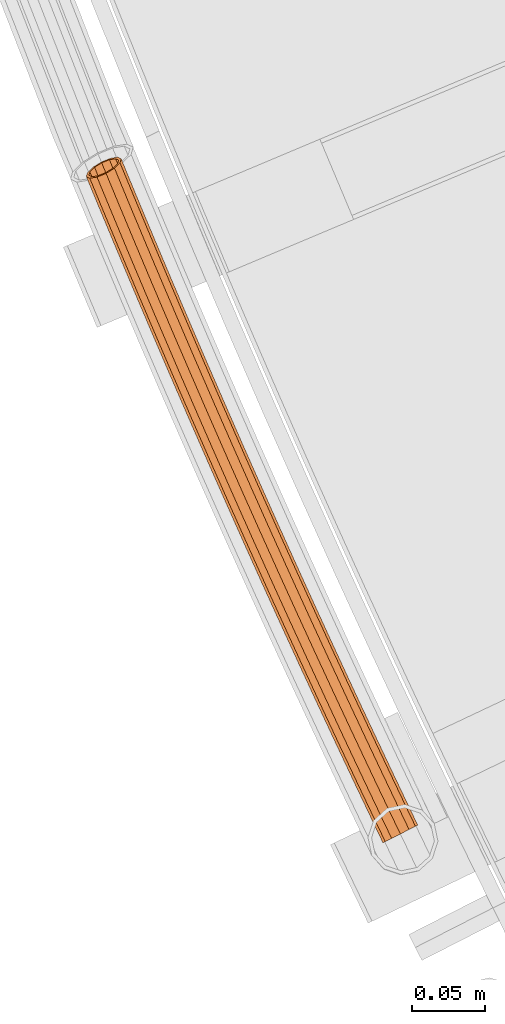
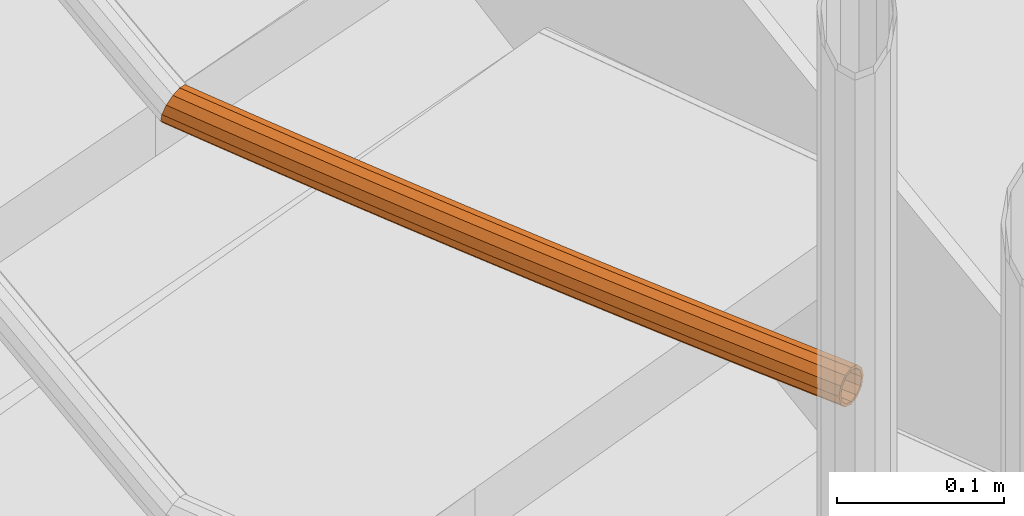
# One storey, part 48 of 126: 1 proxy.
"""IFC2X3 building model written with IfcOpenShell, lengths in millimetres."""

from ifc_helpers import new_model, si_unit, origin, origin_with_axes, place, context, project, spatial, faceted_brep, material, element, save


model = new_model("IFC2X3")

# Units and contexts
context_of_model_1 = context(None, 3, precision=0.1, world=origin())
context_of_model_2 = context(None, 3, precision=0.1, world=origin())
ifc_project = project(units=[si_unit("LENGTHUNIT", "METRE", prefix="MILLI"), si_unit("AREAUNIT", "SQUARE_METRE", prefix="CENTI"), si_unit("VOLUMEUNIT", "CUBIC_METRE", prefix="CENTI"), si_unit("MASSUNIT", "GRAM", prefix="KILO")], contexts=[context_of_model_1, context_of_model_2])

# Site, building, storey
site_placement = place(None, origin_with_axes())
site = spatial("IfcSite", under=ifc_project, at=site_placement, CompositionType="ELEMENT")
building_placement = place(site_placement, origin_with_axes())
building = spatial("IfcBuilding", under=site, at=building_placement, CompositionType="ELEMENT")
storey_placement = place(building_placement, origin_with_axes())
storey = spatial("IfcBuildingStorey", under=building, at=storey_placement, CompositionType="ELEMENT")

# Proxy
ifc_material = material(Name="S235JRG2")
proxy_placement = place(storey_placement, origin_with_axes())
element("IfcBuildingElementProxy", 1, at=proxy_placement, inside=storey, material=ifc_material, context=context_of_model_2, shape_type="Brep", body=[
    faceted_brep([(-4.3297, 4176.1625, 3524.2551), (-2.7039, 4176.9397, 3517.5301), (2.3279, 4166.4608, 3517.5301), (0.7226, 4165.6411, 3524.2551), (1.7377, 4179.063, 3512.607), (6.7137, 4168.7004, 3512.607), (7.805, 4181.9635, 3510.8051), (12.7049, 4171.7596, 3510.8051), (13.8724, 4184.864, 3512.607), (18.696, 4174.8188, 3512.607), (18.314, 4186.9873, 3517.5301), (23.0818, 4177.0583, 3517.5301), (19.9398, 4187.7645, 3524.2551), (24.6872, 4177.878, 3524.2551), (18.314, 4186.9873, 3530.9801), (23.0818, 4177.0583, 3530.9801), (13.8724, 4184.864, 3535.9031), (18.696, 4174.8188, 3535.9031), (7.805, 4181.9635, 3537.7051), (12.7049, 4171.7596, 3537.7051), (1.7377, 4179.063, 3535.9031), (6.7137, 4168.7004, 3535.9031), (-2.7039, 4176.9397, 3530.9801), (2.3279, 4166.4608, 3530.9801), (-2.5253, 4177.0251, 3524.2551), (-1.1413, 4177.6867, 3529.9801), (3.871, 4167.2488, 3529.9801), (2.5044, 4166.5509, 3524.2551), (2.6399, 4179.4943, 3534.1711), (7.6046, 4169.1553, 3534.1711), (7.805, 4181.9635, 3535.7051), (12.7049, 4171.7596, 3535.7051), (12.9702, 4184.4327, 3534.1711), (17.8052, 4174.3639, 3534.1711), (16.7513, 4186.2403, 3529.9801), (21.5388, 4176.2704, 3529.9801), (18.1353, 4186.9019, 3524.2551), (22.9054, 4176.9682, 3524.2551), (16.7513, 4186.2403, 3518.5301), (21.5388, 4176.2704, 3518.5301), (12.9702, 4184.4327, 3514.3391), (17.8052, 4174.3639, 3514.3391), (7.805, 4181.9635, 3512.8051), (12.7049, 4171.7596, 3512.8051), (2.6399, 4179.4943, 3514.3391), (7.6046, 4169.1553, 3514.3391), (-1.1413, 4177.6867, 3518.5301), (3.871, 4167.2488, 3518.5301), (-17.646, 4204.1436, 3524.2551), (-16.0176, 4204.9151, 3517.5301), (-11.5686, 4207.0229, 3512.607), (-5.4911, 4209.9022, 3510.8051), (0.5863, 4212.7815, 3512.607), (5.0353, 4214.8893, 3517.5301), (6.6638, 4215.6608, 3524.2551), (5.0353, 4214.8893, 3530.9801), (0.5863, 4212.7815, 3535.9031), (-5.4911, 4209.9022, 3537.7051), (-11.5686, 4207.0229, 3535.9031), (-16.0176, 4204.9151, 3530.9801), (-15.8386, 4204.9999, 3524.2551), (-14.4523, 4205.6567, 3529.9801), (-10.6649, 4207.4511, 3534.1711), (-5.4911, 4209.9022, 3535.7051), (-0.3174, 4212.3534, 3534.1711), (3.4701, 4214.1477, 3529.9801), (4.8564, 4214.8045, 3524.2551), (3.4701, 4214.1477, 3518.5301), (-0.3174, 4212.3534, 3514.3391), (-5.4911, 4209.9022, 3512.8051), (-10.6649, 4207.4511, 3514.3391), (-14.4523, 4205.6567, 3518.5301), (-30.8646, 4232.171, 3524.2551), (-29.2335, 4232.9369, 3517.5301), (-24.7772, 4235.0291, 3512.607), (-18.6897, 4237.8872, 3510.8051), (-12.6022, 4240.7452, 3512.607), (-8.1459, 4242.8375, 3517.5301), (-6.5148, 4243.6033, 3524.2551), (-8.1459, 4242.8375, 3530.9801), (-12.6022, 4240.7452, 3535.9031), (-18.6897, 4237.8872, 3537.7051), (-24.7772, 4235.0291, 3535.9031), (-29.2335, 4232.9369, 3530.9801), (-29.0542, 4233.021, 3524.2551), (-27.6656, 4233.673, 3529.9801), (-23.872, 4235.4541, 3534.1711), (-18.6897, 4237.8872, 3535.7051), (-13.5074, 4240.3202, 3534.1711), (-9.7137, 4242.1014, 3529.9801), (-8.3252, 4242.7533, 3524.2551), (-9.7137, 4242.1014, 3518.5301), (-13.5074, 4240.3202, 3514.3391), (-18.6897, 4237.8872, 3512.8051), (-23.872, 4235.4541, 3514.3391), (-27.6656, 4233.673, 3518.5301), (-43.9853, 4260.2444, 3524.2551), (-42.3515, 4261.0046, 3517.5301), (-37.8879, 4263.0812, 3512.607), (-31.7905, 4265.918, 3510.8051), (-25.6931, 4268.7548, 3512.607), (-21.2295, 4270.8315, 3517.5301), (-19.5957, 4271.5916, 3524.2551), (-21.2295, 4270.8315, 3530.9801), (-25.6931, 4268.7548, 3535.9031), (-31.7905, 4265.918, 3537.7051), (-37.8879, 4263.0812, 3535.9031), (-42.3515, 4261.0046, 3530.9801), (-42.1719, 4261.0881, 3524.2551), (-40.7811, 4261.7352, 3529.9801), (-36.9812, 4263.5031, 3534.1711), (-31.7905, 4265.918, 3535.7051), (-26.5998, 4268.333, 3534.1711), (-22.7999, 4270.1009, 3529.9801), (-21.409, 4270.7479, 3524.2551), (-22.7999, 4270.1009, 3518.5301), (-26.5998, 4268.333, 3514.3391), (-31.7905, 4265.918, 3512.8051), (-36.9812, 4263.5031, 3514.3391), (-40.7811, 4261.7352, 3518.5301), (-57.0079, 4288.3635, 3524.2551), (-55.3715, 4289.1179, 3517.5301), (-50.9006, 4291.1789, 3512.607), (-44.7934, 4293.9944, 3510.8051), (-38.6861, 4296.8099, 3512.607), (-34.2152, 4298.871, 3517.5301), (-32.5788, 4299.6254, 3524.2551), (-34.2152, 4298.871, 3530.9801), (-38.6861, 4296.8099, 3535.9031), (-44.7934, 4293.9944, 3537.7051), (-50.9006, 4291.1789, 3535.9031), (-55.3715, 4289.1179, 3530.9801), (-55.1916, 4289.2008, 3524.2551), (-53.7985, 4289.843, 3529.9801), (-49.9925, 4291.5976, 3534.1711), (-44.7934, 4293.9944, 3535.7051), (-39.5942, 4296.3913, 3534.1711), (-35.7882, 4298.1459, 3529.9801), (-34.3951, 4298.7881, 3524.2551), (-35.7882, 4298.1459, 3518.5301), (-39.5942, 4296.3913, 3514.3391), (-44.7934, 4293.9944, 3512.8051), (-49.9925, 4291.5976, 3514.3391), (-53.7985, 4289.843, 3518.5301), (-69.9323, 4316.5278, 3524.2551), (-68.2932, 4317.2764, 3517.5301), (-63.8152, 4319.3219, 3512.607), (-57.6981, 4322.1161, 3510.8051), (-51.5811, 4324.9102, 3512.607), (-47.1031, 4326.9557, 3517.5301), (-45.464, 4327.7044, 3524.2551), (-47.1031, 4326.9557, 3530.9801), (-51.5811, 4324.9102, 3535.9031), (-57.6981, 4322.1161, 3537.7051), (-63.8152, 4319.3219, 3535.9031), (-68.2932, 4317.2764, 3530.9801), (-68.1131, 4317.3587, 3524.2551), (-66.7177, 4317.9961, 3529.9801), (-62.9056, 4319.7374, 3534.1711), (-57.6981, 4322.1161, 3535.7051), (-52.4907, 4324.4947, 3534.1711), (-48.6785, 4326.236, 3529.9801), (-47.2832, 4326.8734, 3524.2551), (-48.6785, 4326.236, 3518.5301), (-52.4907, 4324.4947, 3514.3391), (-57.6981, 4322.1161, 3512.8051), (-62.9056, 4319.7374, 3514.3391), (-66.7177, 4317.9961, 3518.5301), (-82.7582, 4344.737, 3524.2551), (-81.1166, 4345.48, 3517.5301), (-76.6315, 4347.5098, 3512.607), (-70.5047, 4350.2826, 3510.8051), (-64.3779, 4353.0554, 3512.607), (-59.8928, 4355.0852, 3517.5301), (-58.2511, 4355.8281, 3524.2551), (-59.8928, 4355.0852, 3530.9801), (-64.3779, 4353.0554, 3535.9031), (-70.5047, 4350.2826, 3537.7051), (-76.6315, 4347.5098, 3535.9031), (-81.1166, 4345.48, 3530.9801), (-80.9361, 4345.5616, 3524.2551), (-79.5386, 4346.1941, 3529.9801), (-75.7204, 4347.9221, 3534.1711), (-70.5047, 4350.2826, 3535.7051), (-65.2889, 4352.643, 3534.1711), (-61.4708, 4354.371, 3529.9801), (-60.0732, 4355.0035, 3524.2551), (-61.4708, 4354.371, 3518.5301), (-65.2889, 4352.643, 3514.3391), (-70.5047, 4350.2826, 3512.8051), (-75.7204, 4347.9221, 3514.3391), (-79.5386, 4346.1941, 3518.5301), (-95.4857, 4372.9908, 3524.2551), (-93.8414, 4373.7281, 3517.5301), (-89.3492, 4375.7422, 3512.607), (-83.2128, 4378.4936, 3510.8051), (-77.0764, 4381.245, 3512.607), (-72.5842, 4383.2591, 3517.5301), (-70.94, 4383.9964, 3524.2551), (-72.5842, 4383.2591, 3530.9801), (-77.0764, 4381.245, 3535.9031), (-83.2128, 4378.4936, 3537.7051), (-89.3492, 4375.7422, 3535.9031), (-93.8414, 4373.7281, 3530.9801), (-93.6607, 4373.8091, 3524.2551), (-92.261, 4374.4367, 3529.9801), (-88.4368, 4376.1514, 3534.1711), (-83.2128, 4378.4936, 3535.7051), (-77.9889, 4380.8359, 3534.1711), (-74.1647, 4382.5505, 3529.9801), (-72.7649, 4383.1781, 3524.2551), (-74.1647, 4382.5505, 3518.5301), (-77.9889, 4380.8359, 3514.3391), (-83.2128, 4378.4936, 3512.8051), (-88.4368, 4376.1514, 3514.3391), (-92.261, 4374.4367, 3518.5301), (-108.1144, 4401.2889, 3524.2551), (-106.4676, 4402.0204, 3517.5301), (-101.9684, 4404.0189, 3512.607), (-95.8224, 4406.7488, 3510.8051), (-89.6764, 4409.4788, 3512.607), (-85.1773, 4411.4772, 3517.5301), (-83.5304, 4412.2087, 3524.2551), (-85.1773, 4411.4772, 3530.9801), (-89.6764, 4409.4788, 3535.9031), (-95.8224, 4406.7488, 3537.7051), (-101.9684, 4404.0189, 3535.9031), (-106.4676, 4402.0204, 3530.9801), (-106.2866, 4402.1008, 3524.2551), (-104.8847, 4402.7235, 3529.9801), (-101.0545, 4404.4248, 3534.1711), (-95.8224, 4406.7488, 3535.7051), (-90.5903, 4409.0728, 3534.1711), (-86.7602, 4410.7741, 3529.9801), (-85.3582, 4411.3968, 3524.2551), (-86.7602, 4410.7741, 3518.5301), (-90.5903, 4409.0728, 3514.3391), (-95.8224, 4406.7488, 3512.8051), (-101.0545, 4404.4248, 3514.3391), (-104.8847, 4402.7235, 3518.5301), (-120.6443, 4429.631, 3524.2551), (-118.9949, 4430.3567, 3517.5301), (-114.4888, 4432.3394, 3512.607), (-108.3333, 4435.0479, 3510.8051), (-102.1778, 4437.7564, 3512.607), (-97.6717, 4439.7391, 3517.5301), (-96.0224, 4440.4649, 3524.2551), (-97.6717, 4439.7391, 3530.9801), (-102.1778, 4437.7564, 3535.9031), (-108.3333, 4435.0479, 3537.7051), (-114.4888, 4432.3394, 3535.9031), (-118.9949, 4430.3567, 3530.9801), (-118.8136, 4430.4364, 3524.2551), (-117.4095, 4431.0543, 3529.9801), (-113.5735, 4432.7422, 3534.1711), (-108.3333, 4435.0479, 3535.7051), (-103.0931, 4437.3536, 3534.1711), (-99.2571, 4439.0415, 3529.9801), (-97.853, 4439.6594, 3524.2551), (-99.2571, 4439.0415, 3518.5301), (-103.0931, 4437.3536, 3514.3391), (-108.3333, 4435.0479, 3512.8051), (-113.5735, 4432.7422, 3514.3391), (-117.4095, 4431.0543, 3518.5301), (-133.0751, 4458.0165, 3524.2551), (-131.4233, 4458.7365, 3517.5301), (-126.9102, 4460.7035, 3512.607), (-120.7453, 4463.3905, 3510.8051), (-114.5804, 4466.0774, 3512.607), (-110.0674, 4468.0444, 3517.5301), (-108.4155, 4468.7644, 3524.2551), (-110.0674, 4468.0444, 3530.9801), (-114.5804, 4466.0774, 3535.9031), (-120.7453, 4463.3905, 3537.7051), (-126.9102, 4460.7035, 3535.9031), (-131.4233, 4458.7365, 3530.9801), (-131.2417, 4458.8156, 3524.2551), (-129.8355, 4459.4285, 3529.9801), (-125.9935, 4461.103, 3534.1711), (-120.7453, 4463.3905, 3535.7051), (-115.4972, 4465.6779, 3534.1711), (-111.6552, 4467.3524, 3529.9801), (-110.249, 4467.9653, 3524.2551), (-111.6552, 4467.3524, 3518.5301), (-115.4972, 4465.6779, 3514.3391), (-120.7453, 4463.3905, 3512.8051), (-125.9935, 4461.103, 3514.3391), (-129.8355, 4459.4285, 3518.5301), (-145.4068, 4486.4453, 3524.2551), (-143.7524, 4487.1595, 3517.5301), (-139.2326, 4489.1108, 3512.607), (-133.0584, 4491.7762, 3510.8051), (-126.8841, 4494.4416, 3512.607), (-122.3643, 4496.3929, 3517.5301), (-120.7099, 4497.1071, 3524.2551), (-122.3643, 4496.3929, 3530.9801), (-126.8841, 4494.4416, 3535.9031), (-133.0584, 4491.7762, 3537.7051), (-139.2326, 4489.1108, 3535.9031), (-143.7524, 4487.1595, 3530.9801), (-143.5706, 4487.238, 3524.2551), (-142.1623, 4487.846, 3529.9801), (-138.3145, 4489.5071, 3534.1711), (-133.0584, 4491.7762, 3535.7051), (-127.8022, 4494.0453, 3534.1711), (-123.9545, 4495.7064, 3529.9801), (-122.5461, 4496.3144, 3524.2551), (-123.9545, 4495.7064, 3518.5301), (-127.8022, 4494.0453, 3514.3391), (-133.0584, 4491.7762, 3512.8051), (-138.3145, 4489.5071, 3514.3391), (-142.1623, 4487.846, 3518.5301), (-157.6392, 4514.917, 3524.2551), (-155.9824, 4515.6254, 3517.5301), (-151.4557, 4517.5609, 3512.607), (-145.2722, 4520.2047, 3510.8051), (-139.0887, 4522.8486, 3512.607), (-134.5621, 4524.784, 3517.5301), (-132.9052, 4525.4925, 3524.2551), (-134.5621, 4524.784, 3530.9801), (-139.0887, 4522.8486, 3535.9031), (-145.2722, 4520.2047, 3537.7051), (-151.4557, 4517.5609, 3535.9031), (-155.9824, 4515.6254, 3530.9801), (-155.8003, 4515.7033, 3524.2551), (-154.3898, 4516.3063, 3529.9801), (-150.5362, 4517.954, 3534.1711), (-145.2722, 4520.2047, 3535.7051), (-140.0082, 4522.4554, 3534.1711), (-136.1547, 4524.1031, 3529.9801), (-134.7442, 4524.7062, 3524.2551), (-136.1547, 4524.1031, 3518.5301), (-140.0082, 4522.4554, 3514.3391), (-145.2722, 4520.2047, 3512.8051), (-150.5362, 4517.954, 3514.3391), (-154.3898, 4516.3063, 3518.5301), (-169.7722, 4543.4312, 3524.2551), (-168.1128, 4544.1338, 3517.5301), (-163.5795, 4546.0534, 3512.607), (-157.3868, 4548.6757, 3510.8051), (-151.1941, 4551.298, 3512.607), (-146.6607, 4553.2176, 3517.5301), (-145.0014, 4553.9202, 3524.2551), (-146.6607, 4553.2176, 3530.9801), (-151.1941, 4551.298, 3535.9031), (-157.3868, 4548.6757, 3537.7051), (-163.5795, 4546.0534, 3535.9031), (-168.1128, 4544.1338, 3530.9801), (-167.9305, 4544.211, 3524.2551), (-166.5179, 4544.8092, 3529.9801), (-162.6586, 4546.4434, 3534.1711), (-157.3868, 4548.6757, 3535.7051), (-152.1149, 4550.9081, 3534.1711), (-148.2557, 4552.5422, 3529.9801), (-146.8431, 4553.1404, 3524.2551), (-148.2557, 4552.5422, 3518.5301), (-152.1149, 4550.9081, 3514.3391), (-157.3868, 4548.6757, 3512.8051), (-162.6586, 4546.4434, 3514.3391), (-166.5179, 4544.8092, 3518.5301), (-181.8055, 4571.9875, 3524.2551), (-180.1437, 4572.6844, 3517.5301), (-175.6037, 4574.5882, 3512.607), (-169.4019, 4577.1888, 3510.8051), (-163.2001, 4579.7895, 3512.607), (-158.66, 4581.6932, 3517.5301), (-156.9982, 4582.3901, 3524.2551), (-158.66, 4581.6932, 3530.9801), (-163.2001, 4579.7895, 3535.9031), (-169.4019, 4577.1888, 3537.7051), (-175.6037, 4574.5882, 3535.9031), (-180.1437, 4572.6844, 3530.9801), (-179.9611, 4572.761, 3524.2551), (-178.5464, 4573.3542, 3529.9801), (-174.6815, 4574.9749, 3534.1711), (-169.4019, 4577.1888, 3535.7051), (-164.1223, 4579.4027, 3534.1711), (-160.2573, 4581.0234, 3529.9801), (-158.8426, 4581.6167, 3524.2551), (-160.2573, 4581.0234, 3518.5301), (-164.1223, 4579.4027, 3514.3391), (-169.4019, 4577.1888, 3512.8051), (-174.6815, 4574.9749, 3514.3391), (-178.5464, 4573.3542, 3518.5301), (-193.7391, 4600.5857, 3524.2551), (-192.0749, 4601.2768, 3517.5301), (-187.5282, 4603.1647, 3512.607), (-181.3174, 4605.7437, 3510.8051), (-175.1065, 4608.3227, 3512.607), (-170.5598, 4610.2106, 3517.5301), (-168.8957, 4610.9016, 3524.2551), (-170.5598, 4610.2106, 3530.9801), (-175.1065, 4608.3227, 3535.9031), (-181.3174, 4605.7437, 3537.7051), (-187.5282, 4603.1647, 3535.9031), (-192.0749, 4601.2768, 3530.9801), (-191.892, 4601.3527, 3524.2551), (-190.4752, 4601.941, 3529.9801), (-186.6047, 4603.5482, 3534.1711), (-181.3174, 4605.7437, 3535.7051), (-176.0301, 4607.9392, 3534.1711), (-172.1595, 4609.5464, 3529.9801), (-170.7427, 4610.1346, 3524.2551), (-172.1595, 4609.5464, 3518.5301), (-176.0301, 4607.9392, 3514.3391), (-181.3174, 4605.7437, 3512.8051), (-186.6047, 4603.5482, 3514.3391), (-190.4752, 4601.941, 3518.5301), (-203.6843, 4624.6551, 3524.2551), (-202.8892, 4627.4495, 3517.5301), (-199.0871, 4631.1393, 3512.607), (-195.5025, 4633.3658, 3511.4915), (-193.1331, 4634.34, 3510.8051), (-186.9133, 4636.8973, 3512.607), (-185.3026, 4637.5595, 3514.3486), (-182.0744, 4638.078, 3517.5301), (-179.6495, 4636.9279, 3524.2551), (-180.4446, 4634.1336, 3530.9801), (-184.2468, 4630.4438, 3535.9031), (-190.0371, 4626.8472, 3537.7051), (-196.2642, 4624.3074, 3535.9031), (-201.2594, 4623.5051, 3530.9801), (-201.8974, 4625.5676, 3524.2551), (-199.833, 4624.5886, 3529.9801), (-195.5806, 4625.2716, 3534.1711), (-190.2795, 4627.4337, 3535.7051), (-185.3501, 4630.4955, 3534.1711), (-182.1134, 4633.6367, 3529.9801), (-181.4365, 4636.0155, 3524.2551), (-183.5008, 4636.9945, 3518.5301), (-187.7533, 4636.3115, 3514.3391), (-193.0544, 4634.1494, 3512.8051), (-197.9837, 4631.0876, 3514.3391), (-201.2205, 4627.9464, 3518.5301), (-193.2954, 4634.7366, 3510.8051), (-187.0684, 4637.2763, 3512.607)], [[[0, 1, 2, 3]], [[1, 4, 5, 2]], [[4, 6, 7, 5]], [[6, 8, 9, 7]], [[8, 10, 11, 9]], [[10, 12, 13, 11]], [[12, 14, 15, 13]], [[14, 16, 17, 15]], [[16, 18, 19, 17]], [[18, 20, 21, 19]], [[20, 22, 23, 21]], [[0, 3, 23, 22]], [[24, 25, 26, 27]], [[25, 28, 29, 26]], [[28, 30, 31, 29]], [[30, 32, 33, 31]], [[32, 34, 35, 33]], [[34, 36, 37, 35]], [[36, 38, 39, 37]], [[38, 40, 41, 39]], [[40, 42, 43, 41]], [[42, 44, 45, 43]], [[44, 46, 47, 45]], [[24, 27, 47, 46]], [[0, 48, 49, 1]], [[1, 49, 50, 4]], [[4, 50, 51, 6]], [[6, 51, 52, 8]], [[8, 52, 53, 10]], [[10, 53, 54, 12]], [[12, 54, 55, 14]], [[14, 55, 56, 16]], [[16, 56, 57, 18]], [[18, 57, 58, 20]], [[20, 58, 59, 22]], [[22, 59, 48, 0]], [[24, 60, 61, 25]], [[25, 61, 62, 28]], [[28, 62, 63, 30]], [[30, 63, 64, 32]], [[32, 64, 65, 34]], [[34, 65, 66, 36]], [[36, 66, 67, 38]], [[38, 67, 68, 40]], [[40, 68, 69, 42]], [[42, 69, 70, 44]], [[44, 70, 71, 46]], [[46, 71, 60, 24]], [[48, 72, 73, 49]], [[49, 73, 74, 50]], [[50, 74, 75, 51]], [[51, 75, 76, 52]], [[52, 76, 77, 53]], [[53, 77, 78, 54]], [[54, 78, 79, 55]], [[55, 79, 80, 56]], [[56, 80, 81, 57]], [[57, 81, 82, 58]], [[58, 82, 83, 59]], [[59, 83, 72, 48]], [[60, 84, 85, 61]], [[61, 85, 86, 62]], [[62, 86, 87, 63]], [[63, 87, 88, 64]], [[64, 88, 89, 65]], [[65, 89, 90, 66]], [[66, 90, 91, 67]], [[67, 91, 92, 68]], [[68, 92, 93, 69]], [[69, 93, 94, 70]], [[70, 94, 95, 71]], [[71, 95, 84, 60]], [[72, 96, 97, 73]], [[73, 97, 98, 74]], [[74, 98, 99, 75]], [[75, 99, 100, 76]], [[76, 100, 101, 77]], [[77, 101, 102, 78]], [[78, 102, 103, 79]], [[79, 103, 104, 80]], [[80, 104, 105, 81]], [[81, 105, 106, 82]], [[82, 106, 107, 83]], [[83, 107, 96, 72]], [[84, 108, 109, 85]], [[85, 109, 110, 86]], [[86, 110, 111, 87]], [[87, 111, 112, 88]], [[88, 112, 113, 89]], [[89, 113, 114, 90]], [[90, 114, 115, 91]], [[91, 115, 116, 92]], [[92, 116, 117, 93]], [[93, 117, 118, 94]], [[94, 118, 119, 95]], [[95, 119, 108, 84]], [[96, 120, 121, 97]], [[97, 121, 122, 98]], [[98, 122, 123, 99]], [[99, 123, 124, 100]], [[100, 124, 125, 101]], [[101, 125, 126, 102]], [[102, 126, 127, 103]], [[103, 127, 128, 104]], [[104, 128, 129, 105]], [[105, 129, 130, 106]], [[106, 130, 131, 107]], [[107, 131, 120, 96]], [[108, 132, 133, 109]], [[109, 133, 134, 110]], [[110, 134, 135, 111]], [[111, 135, 136, 112]], [[112, 136, 137, 113]], [[113, 137, 138, 114]], [[114, 138, 139, 115]], [[115, 139, 140, 116]], [[116, 140, 141, 117]], [[117, 141, 142, 118]], [[118, 142, 143, 119]], [[119, 143, 132, 108]], [[120, 144, 145, 121]], [[121, 145, 146, 122]], [[122, 146, 147, 123]], [[123, 147, 148, 124]], [[124, 148, 149, 125]], [[125, 149, 150, 126]], [[126, 150, 151, 127]], [[127, 151, 152, 128]], [[128, 152, 153, 129]], [[129, 153, 154, 130]], [[130, 154, 155, 131]], [[131, 155, 144, 120]], [[132, 156, 157, 133]], [[133, 157, 158, 134]], [[134, 158, 159, 135]], [[135, 159, 160, 136]], [[136, 160, 161, 137]], [[137, 161, 162, 138]], [[138, 162, 163, 139]], [[139, 163, 164, 140]], [[140, 164, 165, 141]], [[141, 165, 166, 142]], [[142, 166, 167, 143]], [[143, 167, 156, 132]], [[144, 168, 169, 145]], [[145, 169, 170, 146]], [[146, 170, 171, 147]], [[147, 171, 172, 148]], [[148, 172, 173, 149]], [[149, 173, 174, 150]], [[150, 174, 175, 151]], [[151, 175, 176, 152]], [[152, 176, 177, 153]], [[153, 177, 178, 154]], [[154, 178, 179, 155]], [[155, 179, 168, 144]], [[156, 180, 181, 157]], [[157, 181, 182, 158]], [[158, 182, 183, 159]], [[159, 183, 184, 160]], [[160, 184, 185, 161]], [[161, 185, 186, 162]], [[162, 186, 187, 163]], [[163, 187, 188, 164]], [[164, 188, 189, 165]], [[165, 189, 190, 166]], [[166, 190, 191, 167]], [[167, 191, 180, 156]], [[168, 192, 193, 169]], [[169, 193, 194, 170]], [[170, 194, 195, 171]], [[171, 195, 196, 172]], [[172, 196, 197, 173]], [[173, 197, 198, 174]], [[174, 198, 199, 175]], [[175, 199, 200, 176]], [[176, 200, 201, 177]], [[177, 201, 202, 178]], [[178, 202, 203, 179]], [[179, 203, 192, 168]], [[180, 204, 205, 181]], [[181, 205, 206, 182]], [[182, 206, 207, 183]], [[183, 207, 208, 184]], [[184, 208, 209, 185]], [[185, 209, 210, 186]], [[186, 210, 211, 187]], [[187, 211, 212, 188]], [[188, 212, 213, 189]], [[189, 213, 214, 190]], [[190, 214, 215, 191]], [[191, 215, 204, 180]], [[192, 216, 217, 193]], [[193, 217, 218, 194]], [[194, 218, 219, 195]], [[195, 219, 220, 196]], [[196, 220, 221, 197]], [[197, 221, 222, 198]], [[198, 222, 223, 199]], [[199, 223, 224, 200]], [[200, 224, 225, 201]], [[201, 225, 226, 202]], [[202, 226, 227, 203]], [[203, 227, 216, 192]], [[204, 228, 229, 205]], [[205, 229, 230, 206]], [[206, 230, 231, 207]], [[207, 231, 232, 208]], [[208, 232, 233, 209]], [[209, 233, 234, 210]], [[210, 234, 235, 211]], [[211, 235, 236, 212]], [[212, 236, 237, 213]], [[213, 237, 238, 214]], [[214, 238, 239, 215]], [[215, 239, 228, 204]], [[216, 240, 241, 217]], [[217, 241, 242, 218]], [[218, 242, 243, 219]], [[219, 243, 244, 220]], [[220, 244, 245, 221]], [[221, 245, 246, 222]], [[222, 246, 247, 223]], [[223, 247, 248, 224]], [[224, 248, 249, 225]], [[225, 249, 250, 226]], [[226, 250, 251, 227]], [[227, 251, 240, 216]], [[228, 252, 253, 229]], [[229, 253, 254, 230]], [[230, 254, 255, 231]], [[231, 255, 256, 232]], [[232, 256, 257, 233]], [[233, 257, 258, 234]], [[234, 258, 259, 235]], [[235, 259, 260, 236]], [[236, 260, 261, 237]], [[237, 261, 262, 238]], [[238, 262, 263, 239]], [[239, 263, 252, 228]], [[240, 264, 265, 241]], [[241, 265, 266, 242]], [[242, 266, 267, 243]], [[243, 267, 268, 244]], [[244, 268, 269, 245]], [[245, 269, 270, 246]], [[246, 270, 271, 247]], [[247, 271, 272, 248]], [[248, 272, 273, 249]], [[249, 273, 274, 250]], [[250, 274, 275, 251]], [[251, 275, 264, 240]], [[252, 276, 277, 253]], [[253, 277, 278, 254]], [[254, 278, 279, 255]], [[255, 279, 280, 256]], [[256, 280, 281, 257]], [[257, 281, 282, 258]], [[258, 282, 283, 259]], [[259, 283, 284, 260]], [[260, 284, 285, 261]], [[261, 285, 286, 262]], [[262, 286, 287, 263]], [[263, 287, 276, 252]], [[264, 288, 289, 265]], [[265, 289, 290, 266]], [[266, 290, 291, 267]], [[267, 291, 292, 268]], [[268, 292, 293, 269]], [[269, 293, 294, 270]], [[270, 294, 295, 271]], [[271, 295, 296, 272]], [[272, 296, 297, 273]], [[273, 297, 298, 274]], [[274, 298, 299, 275]], [[275, 299, 288, 264]], [[276, 300, 301, 277]], [[277, 301, 302, 278]], [[278, 302, 303, 279]], [[279, 303, 304, 280]], [[280, 304, 305, 281]], [[281, 305, 306, 282]], [[282, 306, 307, 283]], [[283, 307, 308, 284]], [[284, 308, 309, 285]], [[285, 309, 310, 286]], [[286, 310, 311, 287]], [[287, 311, 300, 276]], [[288, 312, 313, 289]], [[289, 313, 314, 290]], [[290, 314, 315, 291]], [[291, 315, 316, 292]], [[292, 316, 317, 293]], [[293, 317, 318, 294]], [[294, 318, 319, 295]], [[295, 319, 320, 296]], [[296, 320, 321, 297]], [[297, 321, 322, 298]], [[298, 322, 323, 299]], [[299, 323, 312, 288]], [[300, 324, 325, 301]], [[301, 325, 326, 302]], [[302, 326, 327, 303]], [[303, 327, 328, 304]], [[304, 328, 329, 305]], [[305, 329, 330, 306]], [[306, 330, 331, 307]], [[307, 331, 332, 308]], [[308, 332, 333, 309]], [[309, 333, 334, 310]], [[310, 334, 335, 311]], [[311, 335, 324, 300]], [[312, 336, 337, 313]], [[313, 337, 338, 314]], [[314, 338, 339, 315]], [[315, 339, 340, 316]], [[316, 340, 341, 317]], [[317, 341, 342, 318]], [[318, 342, 343, 319]], [[319, 343, 344, 320]], [[320, 344, 345, 321]], [[321, 345, 346, 322]], [[322, 346, 347, 323]], [[323, 347, 336, 312]], [[324, 348, 349, 325]], [[325, 349, 350, 326]], [[326, 350, 351, 327]], [[327, 351, 352, 328]], [[328, 352, 353, 329]], [[329, 353, 354, 330]], [[330, 354, 355, 331]], [[331, 355, 356, 332]], [[332, 356, 357, 333]], [[333, 357, 358, 334]], [[334, 358, 359, 335]], [[335, 359, 348, 324]], [[336, 360, 361, 337]], [[337, 361, 362, 338]], [[338, 362, 363, 339]], [[339, 363, 364, 340]], [[340, 364, 365, 341]], [[341, 365, 366, 342]], [[342, 366, 367, 343]], [[343, 367, 368, 344]], [[344, 368, 369, 345]], [[345, 369, 370, 346]], [[346, 370, 371, 347]], [[347, 371, 360, 336]], [[348, 372, 373, 349]], [[349, 373, 374, 350]], [[350, 374, 375, 351]], [[351, 375, 376, 352]], [[352, 376, 377, 353]], [[353, 377, 378, 354]], [[354, 378, 379, 355]], [[355, 379, 380, 356]], [[356, 380, 381, 357]], [[357, 381, 382, 358]], [[358, 382, 383, 359]], [[359, 383, 372, 348]], [[360, 384, 385, 361]], [[361, 385, 386, 362]], [[362, 386, 387, 363]], [[363, 387, 388, 364]], [[364, 388, 389, 365]], [[365, 389, 390, 366]], [[366, 390, 391, 367]], [[367, 391, 392, 368]], [[368, 392, 393, 369]], [[369, 393, 394, 370]], [[370, 394, 395, 371]], [[371, 395, 384, 360]], [[372, 396, 397, 373]], [[373, 397, 398, 374]], [[374, 398, 399, 375]], [[375, 399, 400, 376]], [[376, 400, 401, 377]], [[377, 401, 402, 378]], [[378, 402, 403, 379]], [[379, 403, 404, 380]], [[380, 404, 405, 381]], [[381, 405, 406, 382]], [[382, 406, 407, 383]], [[383, 407, 396, 372]], [[384, 408, 409, 385]], [[385, 409, 410, 386]], [[386, 410, 411, 412, 387]], [[387, 412, 413, 388]], [[388, 413, 414, 415, 389]], [[389, 415, 416, 390]], [[390, 416, 417, 391]], [[391, 417, 418, 392]], [[392, 418, 419, 393]], [[393, 419, 420, 394]], [[394, 420, 421, 395]], [[384, 395, 421, 408]], [[396, 422, 423, 397]], [[397, 423, 424, 398]], [[398, 424, 425, 399]], [[399, 425, 426, 400]], [[400, 426, 427, 401]], [[401, 427, 428, 402]], [[402, 428, 429, 403]], [[403, 429, 430, 404]], [[404, 430, 431, 405]], [[405, 431, 432, 406]], [[406, 432, 433, 407]], [[396, 407, 433, 422]], [[411, 434, 412]], [[412, 434, 435, 413]], [[413, 435, 414]], [[7, 9, 11, 13, 15, 17, 19, 21, 23, 3, 2, 5], [26, 29, 31, 33, 35, 37, 39, 41, 43, 45, 47, 27]], [[408, 421, 420, 419, 418, 417, 416, 415, 414, 435, 434, 411, 410, 409], [422, 433, 432, 431, 430, 429, 428, 427, 426, 425, 424, 423]]]),
])

save(model, "model.ifc")
